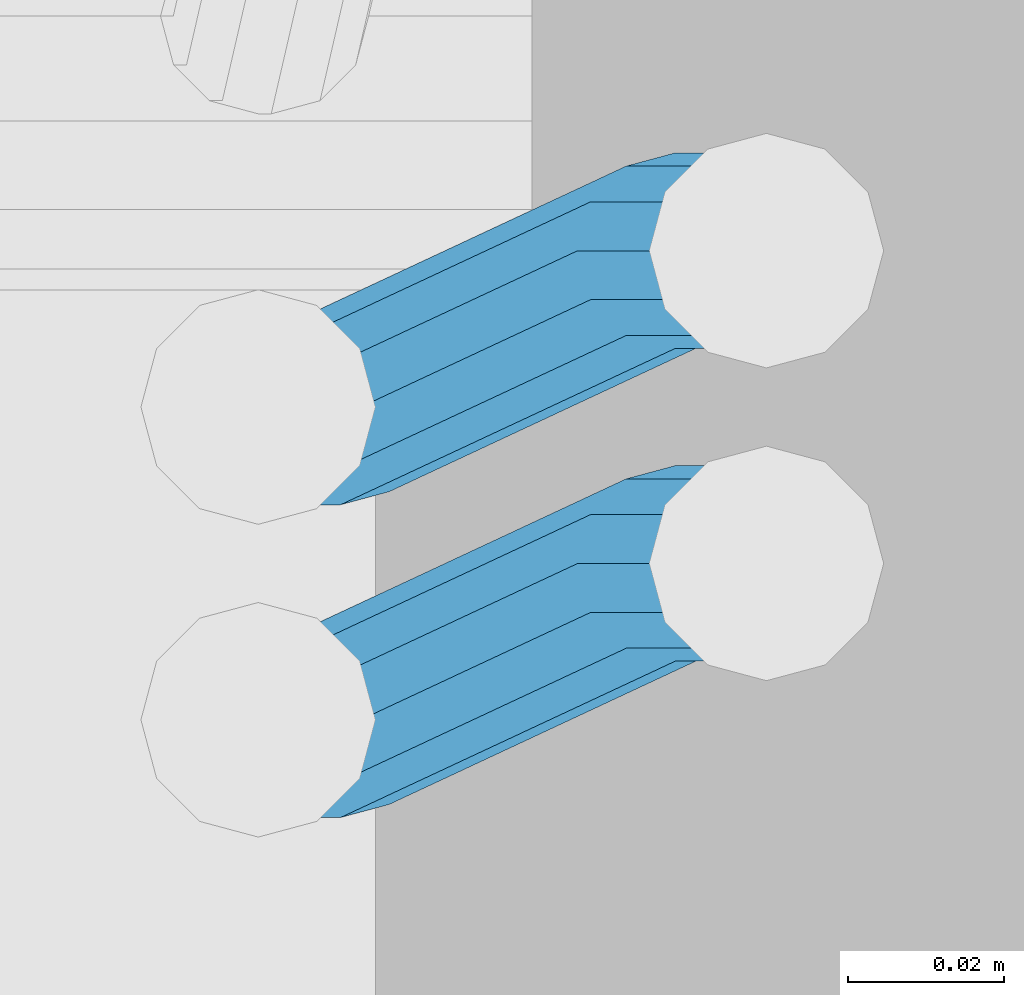
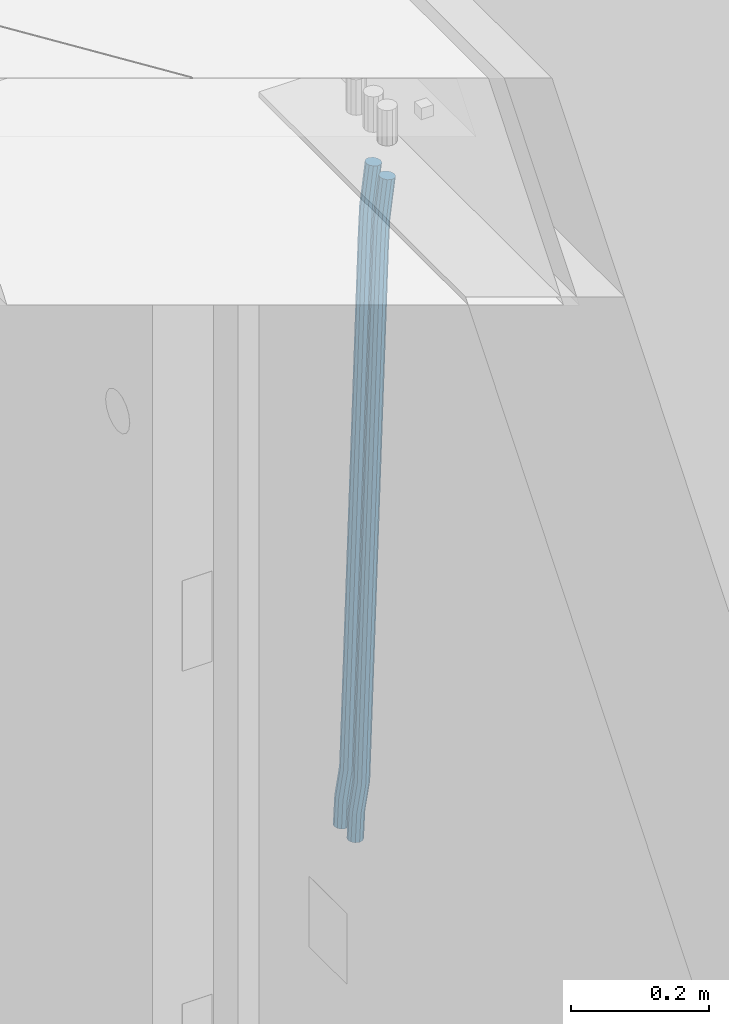
# One storey, part 103 of 309: 2 beams, 1 element without a shape of its own.
"""IFC2X3 building model written with IfcOpenShell, lengths in millimetres."""

import ifcopenshell
import ifcopenshell.guid

model = None  # the IFC model being written
_history = None  # IfcOwnerHistory: only IFC2X3 demands one
_inside = {}  # id of a spatial element -> (the spatial element, [elements in it])
_under = {}  # id of a project, library or spatial element -> (it, [spatial elements below it])
_declared = {}  # id of a project -> (the project, [libraries it declares])
_typed = {}  # id of a type object -> (the type object, [elements of that type])
_made_of = {}  # id of a material, layer set ... -> (it, [elements and type objects made of it])


def new_model(schema):
    """Start an empty IFC model of exactly this schema.

    Asked for "IFC4X3", IfcOpenShell would pick the latest addendum, in which some entities
    have other attributes; the version numbers below select the first issue.
    IFC2X3 requires an IfcOwnerHistory on every rooted entity: one is made here for all.
    """
    global model, _history
    if schema == "IFC4X3":
        model = ifcopenshell.file(schema_version=(4, 3, 0, 0))
    else:
        model = ifcopenshell.file(schema=schema)
    _inside.clear()
    _under.clear()
    _declared.clear()
    _typed.clear()
    _made_of.clear()
    _history = None
    if model.schema == "IFC2X3":
        org = make("IfcOrganization", Name="unknown")
        user = make(
            "IfcPersonAndOrganization",
            ThePerson=make("IfcPerson", FamilyName="unknown"),
            TheOrganization=org,
        )
        app = make(
            "IfcApplication",
            ApplicationDeveloper=org,
            Version="unknown",
            ApplicationFullName="unknown",
            ApplicationIdentifier="unknown",
        )
        _history = make(
            "IfcOwnerHistory",
            OwningUser=user,
            OwningApplication=app,
            ChangeAction="ADDED",
            CreationDate=0,
        )
    return model


def make(cls, **values):
    """One entity of the class cls with the attributes given. An attribute that is None is left unset."""
    return model.create_entity(
        cls, **{name: value for name, value in values.items() if value is not None}
    )


def rooted(cls, **values):
    """An entity with a GlobalId (a new one), such as an element, a storey or a relation."""
    return make(cls, GlobalId=ifcopenshell.guid.new(), OwnerHistory=_history, **values)


def si_unit(unit_type, name, prefix=None):
    """IfcSIUnit, for example si_unit("LENGTHUNIT", "METRE", prefix="MILLI")."""
    return make("IfcSIUnit", UnitType=unit_type, Prefix=prefix, Name=name)


def assignment(units):
    """IfcUnitAssignment: the units of a project."""
    return None if units is None else make("IfcUnitAssignment", Units=units)


def point(xyz):
    """IfcCartesianPoint."""
    return None if xyz is None else make("IfcCartesianPoint", Coordinates=xyz)


def direction(xyz):
    """IfcDirection."""
    return None if xyz is None else make("IfcDirection", DirectionRatios=xyz)


def frame(location, z_axis=None, x_axis=None):
    """IfcAxis2Placement3D, a coordinate frame: its origin and axes. An axis left out is left unset."""
    return make(
        "IfcAxis2Placement3D",
        Location=point(location),
        Axis=direction(z_axis),
        RefDirection=direction(x_axis),
    )


def origin_with_axes():
    """The frame at (0, 0, 0) with the z axis (0, 0, 1) and the x axis (1, 0, 0) written out."""
    return frame((0.0, 0.0, 0.0), z_axis=(0.0, 0.0, 1.0), x_axis=(1.0, 0.0, 0.0))


def place(relative_to, where):
    """IfcLocalPlacement: puts the frame where relative to a parent placement (None: the world)."""
    return make(
        "IfcLocalPlacement", PlacementRelTo=relative_to, RelativePlacement=where
    )


def context(
    kind, dimensions, precision=None, world=None, true_north=None, identifier=None
):
    """IfcGeometricRepresentationContext, for example the 3D "Model" context."""
    return make(
        "IfcGeometricRepresentationContext",
        ContextIdentifier=identifier,
        ContextType=kind,
        CoordinateSpaceDimension=dimensions,
        Precision=precision,
        WorldCoordinateSystem=world,
        TrueNorth=true_north,
    )


def subcontext(parent, identifier, kind, view, scale=None):
    """IfcGeometricRepresentationSubContext, for example "Body" below "Model"."""
    return make(
        "IfcGeometricRepresentationSubContext",
        ContextIdentifier=identifier,
        ContextType=kind,
        ParentContext=parent,
        TargetScale=scale,
        TargetView=view,
    )


def project(units=None, contexts=None):
    """IfcProject with its units and contexts."""
    return rooted(
        "IfcProject",
        Name="project",
        RepresentationContexts=contexts,
        UnitsInContext=assignment(units),
    )


def spatial(cls, under=None, at=None, **own):
    """A site, building, storey or space (cls), placed at a placement, below another one or the project."""
    s = rooted(cls, ObjectPlacement=at, **own)
    if under is not None:
        _under.setdefault(under.id(), (under, []))[1].append(s)
    return s


def faces_of(points, faces, orient=None, outer=None):
    """IfcFace entities. A face is a list of loops; a loop is a list of indices into points, from 0.

    orient and outer hold one flag for each loop. By default every Orientation is true, the
    first loop of a face is its IfcFaceOuterBound and the others are IfcFaceBound.
    """
    made = []
    for i, loops in enumerate(faces):
        bounds = []
        for j, loop in enumerate(loops):
            is_outer = j == 0 if outer is None else outer[i][j]
            bounds.append(
                make(
                    "IfcFaceOuterBound" if is_outer else "IfcFaceBound",
                    Bound=make("IfcPolyLoop", Polygon=[points[k] for k in loop]),
                    Orientation=True if orient is None else orient[i][j],
                )
            )
        made.append(make("IfcFace", Bounds=bounds))
    return made


def faceted_brep(points, faces, orient=None, outer=None, voids=None):
    """IfcFacetedBrep: a solid bounded by flat faces; with voids (closed shells), ...WithVoids."""
    shared = [point(p) for p in points]
    hull = make("IfcClosedShell", CfsFaces=faces_of(shared, faces, orient, outer))
    if voids is None:
        return make("IfcFacetedBrep", Outer=hull)
    return make(
        "IfcFacetedBrepWithVoids",
        Outer=hull,
        Voids=[
            make(cls, CfsFaces=faces_of(shared, fs, o, b)) for cls, fs, o, b in voids
        ],
    )


def shape(context_of_items, identifier, shape_type, items):
    """IfcShapeRepresentation: the items that make up one representation, for example the "Body"."""
    return make(
        "IfcShapeRepresentation",
        ContextOfItems=context_of_items,
        RepresentationIdentifier=identifier,
        RepresentationType=shape_type,
        Items=items,
    )


def material(Name=None, Category=None):
    """IfcMaterial."""
    return make("IfcMaterial", Name=Name, Category=Category)


def made_of(thing, what):
    """Note that an element or type object is made of a material, layer set ...; save() writes the relation."""
    if what is not None:
        _made_of.setdefault(what.id(), (what, []))[1].append(thing)
    return thing


def type_object(cls, material=None, **own):
    """A type object (cls), such as IfcWallType, which elements share."""
    return made_of(rooted(cls, **own), material)


def element(
    cls,
    number,
    at=None,
    inside=None,
    cuts=None,
    type_object=None,
    material=None,
    context=None,
    identifier="Body",
    shape_type=None,
    held_by="IfcProductDefinitionShape",
    body=None,
    shapes=None,
    **own,
):
    """One element of the class cls, such as IfcWall. Its Tag is "e" and its number.

    at: its placement. inside: the storey or other place that contains it. cuts: it is an
    opening in that element (IfcRelVoidsElement). A single representation is given by context,
    identifier, shape_type and body (its items); several are given by shapes. held_by: the class
    of the entity that holds the representations. save() writes the other relations.
    """
    e = rooted(cls, Tag="e%d" % number, ObjectPlacement=at, **own)
    if body is not None:
        shapes = [shape(context, identifier, shape_type, body)]
    if shapes is not None:
        e.Representation = make(held_by, Representations=shapes)
    if inside is not None:
        _inside.setdefault(inside.id(), (inside, []))[1].append(e)
    if cuts is not None:
        rooted(
            "IfcRelVoidsElement", RelatingBuildingElement=cuts, RelatedOpeningElement=e
        )
    if type_object is not None:
        _typed.setdefault(type_object.id(), (type_object, []))[1].append(e)
    return made_of(e, material)


def aggregate(whole, parts):
    """IfcRelAggregates: a whole, such as a stair, and the parts it consists of."""
    return rooted("IfcRelAggregates", RelatingObject=whole, RelatedObjects=parts)


def save(model, path):
    """Write the relations noted so far, then the file.

    IfcRelAggregates (storeys below a building ...), IfcRelContainedInSpatialStructure (elements
    in a storey), IfcRelDefinesByType, IfcRelAssociatesMaterial and IfcRelDeclares: one each for
    every whole, place, type object, material and project.
    """
    for whole, parts in _under.values():
        aggregate(whole, parts)
    for where, things in _inside.values():
        rooted(
            "IfcRelContainedInSpatialStructure",
            RelatedElements=things,
            RelatingStructure=where,
        )
    for kind, things in _typed.values():
        rooted("IfcRelDefinesByType", RelatedObjects=things, RelatingType=kind)
    for what, things in _made_of.values():
        rooted("IfcRelAssociatesMaterial", RelatedObjects=things, RelatingMaterial=what)
    for by, libraries in _declared.values():
        rooted("IfcRelDeclares", RelatingContext=by, RelatedDefinitions=libraries)
    model.write(path)


model = new_model("IFC2X3")

# Units and contexts
model_context = context("Model", 3, precision=1e-05, world=origin_with_axes())
body_context = subcontext(model_context, "Body", "Model", "MODEL_VIEW")
ifc_project = project(units=[si_unit("LENGTHUNIT", "METRE", prefix="MILLI"), si_unit("AREAUNIT", "SQUARE_METRE"), si_unit("VOLUMEUNIT", "CUBIC_METRE"), si_unit("MASSUNIT", "GRAM", prefix="KILO"), si_unit("TIMEUNIT", "SECOND"), si_unit("PLANEANGLEUNIT", "RADIAN"), si_unit("SOLIDANGLEUNIT", "STERADIAN"), si_unit("THERMODYNAMICTEMPERATUREUNIT", "DEGREE_CELSIUS"), si_unit("LUMINOUSINTENSITYUNIT", "LUMEN")], contexts=[model_context])

# Site, building, storey
site_placement = place(None, origin_with_axes())
site = spatial("IfcSite", under=ifc_project, at=site_placement, CompositionType="ELEMENT")
building_placement = place(site_placement, origin_with_axes())
building = spatial("IfcBuilding", under=site, at=building_placement, CompositionType="ELEMENT")
storey_placement = place(building_placement, origin_with_axes())
storey = spatial("IfcBuildingStorey", under=building, at=storey_placement, Name="7", CompositionType="ELEMENT", Elevation=0.0)

# Assembly, beams
assembly_placement = place(storey_placement, origin_with_axes())
assembly = element("IfcElementAssembly", 1, at=assembly_placement, inside=storey, AssemblyPlace="NOTDEFINED", PredefinedType="REINFORCEMENT_UNIT")
ifc_material = material()
beam_type = type_object("IfcBeamType", Name="D25", PredefinedType="NOTDEFINED")
beam_1_placement = place(assembly_placement, frame((17644.9989431251, 20156.4982803956, 101267.503552501), z_axis=(0.0, 1.0, 0.0), x_axis=(0.0467115440025518, 0.0, 0.998908420055061)))
beam_1 = element("IfcBeam", 2, at=beam_1_placement, type_object=beam_type, material=ifc_material, Name="JM25", ObjectType="D25", context=body_context, shape_type="Brep", body=[
    faceted_brep([(-7.41420080885291e-08, -12.5, -3.63797880709171e-12), (-6.42030499875546e-08, -10.8253175473074, -6.25000000000364), (48.7743672639481, -10.8253174221936, -6.25), (48.7743672682554, -12.4999998748863, 0.0), (-3.70782800018787e-08, -6.25000000000364, -10.8253175473074), (48.7743672522192, -6.24999987488263, -10.8253175473037), (-1.45519152283669e-11, -3.63797880709171e-12, -12.5), (48.7743672361976, 1.25113729154691e-07, -12.5), (3.70637280866504e-08, 6.25, -10.8253175473074), (48.7743672201614, 6.25000012511737, -10.8253175473037), (6.42030499875546e-08, 10.8253175473001, -6.25000000000364), (48.774367208418, 10.8253176724174, -6.25), (7.41420080885291e-08, 12.4999999999927, 0.0), (48.7743672041252, 12.5000001251174, 0.0), (6.42176019027829e-08, 10.8253175473001, 6.24999999999636), (48.774367208418, 10.8253176724174, 6.25), (3.70928319171071e-08, 6.24999999999636, 10.8253175473037), (48.7743672201614, 6.25000012511737, 10.8253175473037), (1.45519152283669e-11, -3.63797880709171e-12, 12.4999999999964), (48.7743672361976, 1.25113729154691e-07, 12.5), (-3.7049176171422e-08, -6.25000000000364, 10.8253175473001), (48.7743672522192, -6.24999987488263, 10.8253175473037), (-6.41884980723262e-08, -10.8253175473074, 6.25), (48.7743672639481, -10.8253174221936, 6.25), (50.6284132863948, -10.8253174174351, -6.25), (50.7256294211547, -12.4999998698804, 0.0), (50.362813866901, -6.2499998708081, -10.8253175473037), (49.9999983126327, 1.28262399812229e-07, -12.5), (49.6371827583935, 6.25000012732926, -10.8253175473037), (49.3715833388851, 10.8253176739527, -6.25), (49.2743672041252, 12.5000001264016, 0.0), (49.3715833388851, 10.8253176739527, 6.25), (49.6371827583935, 6.25000012732926, 10.8253175473037), (49.9999983126327, 1.28262399812229e-07, 12.5), (50.362813866901, -6.2499998708081, 10.8253175473037), (50.6284132863948, -10.8253174174351, 6.25), (52.4700055286376, -10.6107838149001, -6.25), (52.6637847850943, -12.2742172873113, 0.0), (51.9405907545442, -6.0661990532717, -10.8253175473037), (51.2173967239651, 0.141819180764287, -12.5), (50.494202693415, 6.34983741480755, -10.8253175473037), (49.9647879192926, 10.8944221764359, -6.25), (49.7710086628358, 12.5578556488472, 0.0), (49.9647879192926, 10.8944221764359, 6.25), (50.494202693415, 6.34983741480755, 10.8253175473037), (51.2173967239651, 0.141819180764287, 12.5), (51.9405907545442, -6.0661990532717, 10.8253175473037), (52.4700055286376, -10.6107838149037, 6.25), (100.1682419055, -5.05424733003747, -6.25), (100.362021161956, -6.71768080244692, 0.0), (99.6388271314063, -0.509662568409112, -10.8253175473037), (98.9156331008271, 5.69835566563052, -12.5), (98.192439070277, 11.9063738996665, -10.8253175473037), (97.6630242961546, 16.4509586612985, -6.25), (97.4692450396979, 18.1143921337098, 0.0), (97.6630242961546, 16.4509586612985, 6.25), (98.192439070277, 11.9063738996665, 10.8253175473037), (98.9156331008271, 5.69835566563052, 12.5), (99.6388271314063, -0.509662568409112, 10.8253175473037), (100.1682419055, -5.05424733003747, 6.25), (100.829389846811, -4.97722786481609, -6.25), (100.858662620667, -6.65982528000313, 0.0), (100.613505361369, -0.39611884945225, -10.8253175473037), (100.268855237926, 5.8559973049887, -12.5), (99.8877881987282, 12.1038711239344, -10.8253175473037), (99.5724108491268, 16.6733898631865, -6.25), (99.4072282953421, 18.3401546667665, 0.0), (99.4365010692127, 16.6575572515831, 6.25), (99.6523855546402, 12.0764482362174, 10.8253175473037), (99.9970356780832, 5.82433208178009, 12.5), (100.37810271731, -0.423541737165579, 10.8253175473037), (100.693480066882, -4.99306047642312, 6.25), (101.494850382805, -4.9772278650471, -6.23547852116099), (101.358543616545, -6.65982528017412, 0.0109082521194068), (101.594541309358, -0.396118849792401, -10.8039096771354), (101.63090429295, 5.85599730451395, -12.4702777768798), (101.594195901474, 12.1038711233377, -10.7880808337759), (101.49425211882, 16.6733898625134, -6.2080621602363), (101.357852800793, 18.340154666088, 0.0425659388420172), (101.221546034547, 16.6575572509591, 6.28895271212241), (101.121855107995, 12.0764482357044, 10.8573838680968), (101.085492124403, 5.82433208139992, 12.5237519678412), (101.122200515863, -0.423541737425694, 10.8415550247373), (101.222144298532, -4.99306047660866, 6.26153635119772), (1016.15234243186, -4.97722818425427, 13.7239010304511), (1016.01603566563, -6.65982559938311, 19.9702878037351), (1016.25203335841, -0.396119168995938, 9.15546987447669), (1016.28839634202, 5.85599698530859, 7.48910177473226), (1016.25168795056, 12.1038708041378, 9.17129871783618), (1016.15174416787, 16.6733895433135, 13.7513173913758), (1016.01534484986, 18.3401543468826, 20.0019454904541), (1015.8790380836, 16.6575569317556, 26.2483322637381), (1015.77934715705, 12.0764479165045, 30.8167634197125), (1015.74298417347, 5.82433176219456, 32.4831315194569), (1015.77969256493, -0.423542056632868, 30.8009345763494), (1015.8796363476, -4.99306079580856, 26.2209159028134), (1016.72024271244, -4.97722818445254, 13.7362935788587), (1016.65208128402, -6.65982559960139, 19.984167399125), (1016.77009392806, -0.396119169179656, 9.16677483576495), (1016.7882773379, 5.85599698513579, 7.50001002685531), (1016.76992071191, 12.1038708039559, 9.18260743664359), (1016.71994269331, 16.6733895431171, 13.7637164479929), (1016.65173485172, 18.3401543466607, 20.015832600875), (1016.58357342328, 16.65755693151, 26.2637064211413), (1016.53372220766, 12.0764479162353, 30.833225164235), (1016.51553879784, 5.82433176192717, 32.4999899731447), (1016.53389542381, -0.423542056894803, 30.8173925633564), (1016.58387344243, -4.99306079605594, 26.2362835520071), (1017.28827819017, -4.97722813975997, 13.7362935788587), (1017.28827832255, -6.6598255495519, 19.984167399125), (1017.28827782976, -0.396119128414284, 9.16677483576495), (1017.28827733788, 5.85599702447144, 7.50001002685531), (1017.28827684635, 12.103870844734, 9.18260743664359), (1017.28827648686, 16.6733895878278, 13.7637164479929), (1017.28827635571, 18.3401543967448, 20.015832600875), (1017.28827648809, 16.657556986951, 26.2637064211413), (1017.2882768485, 12.0764479756035, 30.833225164235), (1017.28827734038, 5.8243318227178, 32.4999899731447), (1017.28827783192, -0.423541997544817, 30.8173925633564), (1017.28827819142, -4.99306074063679, 26.2362835520071), (1065.6667756622, -4.97722433367016, 13.7362935788587), (1065.66677579457, -6.65982174345845, 19.984167399125), (1065.6667753018, -0.3961153223172, 9.16677483576495), (1065.66677480991, 5.85600083056488, 7.50001002685531), (1065.66677431838, 12.1038746508275, 9.18260743664359), (1065.66677395887, 16.6733933939249, 13.7637164479929), (1065.66677382775, 18.3401582028346, 20.015832600875), (1065.66677396011, 16.6575607930445, 26.2637064211413), (1065.66677432053, 12.0764517816933, 30.833225164235), (1065.6667748124, 5.82433562881488, 32.4999899731447), (1065.66677530395, -0.423538191451371, 30.8173925633564), (1065.66677566344, -4.99305693454517, 26.2362835520071), (1067.07165110651, -4.97722422314291, 13.7362935788587), (1067.13694763639, -6.65982162779255, 19.984167399125), (1066.89387208481, -0.396115225779795, 9.16677483576495), (1066.6512463166, 5.85600090801745, 7.50001002685531), (1066.40878518049, 12.1038747092061, 9.18260743664359), (1066.23145594214, 16.6733934383519, 13.7637164479929), (1066.16677382775, 18.340158242172, 20.015832600875), (1066.23207035761, 16.6575608375188, 26.2637064211413), (1066.40984937931, 12.0764518401556, 30.833225164235), (1066.65247514757, 5.82433570636204, 32.4999899731447), (1066.89493628364, -0.423538094826654, 30.8173925633564), (1067.07226552199, -4.99305682397062, 26.2362835520071), (1068.47230333716, -4.86837412698696, 13.736334784764), (1068.60269804588, -6.54588751704068, 19.9842150143704), (1068.11728165975, -0.301059828409052, 9.16679859123906), (1067.63276078545, 5.93224720081525, 7.50000996663584), (1067.14856769117, 12.161337376032, 9.18258357686864), (1066.79444152558, 16.7171310152116, 13.7636751818718), (1066.66527010873, 18.3789068918468, 20.0157849856296), (1066.79566481744, 16.7013935018003, 26.263665215236), (1067.15068649485, 12.134079203217, 30.8332014087609), (1067.63520736917, 5.90077217399266, 32.4999900333642), (1068.11940046342, -0.328318001224034, 30.8174164231314), (1068.47352662902, -4.88411164040008, 26.2363248181282), (1142.62319484423, 0.89544508106701, 13.736334784764), (1142.75358955294, -0.782068308983071, 19.9842150143704), (1142.26817316683, 5.4627593796431, 9.16679859123906), (1141.78365229251, 11.6960664088729, 7.50000996663584), (1141.29945919824, 17.9251565840896, 9.18258357686864), (1140.94533303265, 22.4809502232638, 13.7636751818718), (1140.81616161579, 24.1427260999008, 20.0157849856296), (1140.94655632452, 22.4652127098525, 26.263665215236), (1141.30157800192, 17.8978984112746, 30.8332014087609), (1141.78609887623, 11.6645913820466, 32.4999900333642), (1142.27029197049, 5.43550120682994, 30.8174164231314), (1142.6244181361, 0.879707567652076, 26.2363248181282)], [[[0, 1, 2, 3]], [[1, 4, 5, 2]], [[4, 6, 7, 5]], [[6, 8, 9, 7]], [[8, 10, 11, 9]], [[10, 12, 13, 11]], [[12, 14, 15, 13]], [[14, 16, 17, 15]], [[16, 18, 19, 17]], [[18, 20, 21, 19]], [[20, 22, 23, 21]], [[22, 0, 3, 23]], [[22, 20, 18, 16, 14, 12, 10, 8, 6, 4, 1, 0]], [[3, 2, 24, 25]], [[2, 5, 26, 24]], [[5, 7, 27, 26]], [[7, 9, 28, 27]], [[9, 11, 29, 28]], [[11, 13, 30, 29]], [[13, 15, 31, 30]], [[15, 17, 32, 31]], [[17, 19, 33, 32]], [[19, 21, 34, 33]], [[21, 23, 35, 34]], [[23, 3, 25, 35]], [[25, 24, 36, 37]], [[24, 26, 38, 36]], [[26, 27, 39, 38]], [[27, 28, 40, 39]], [[28, 29, 41, 40]], [[29, 30, 42, 41]], [[30, 31, 43, 42]], [[31, 32, 44, 43]], [[32, 33, 45, 44]], [[33, 34, 46, 45]], [[34, 35, 47, 46]], [[35, 25, 37, 47]], [[37, 36, 48, 49]], [[36, 38, 50, 48]], [[38, 39, 51, 50]], [[39, 40, 52, 51]], [[40, 41, 53, 52]], [[41, 42, 54, 53]], [[42, 43, 55, 54]], [[43, 44, 56, 55]], [[44, 45, 57, 56]], [[45, 46, 58, 57]], [[46, 47, 59, 58]], [[47, 37, 49, 59]], [[49, 48, 60, 61]], [[48, 50, 62, 60]], [[50, 51, 63, 62]], [[51, 52, 64, 63]], [[52, 53, 65, 64]], [[53, 54, 66, 65]], [[54, 55, 67, 66]], [[55, 56, 68, 67]], [[56, 57, 69, 68]], [[57, 58, 70, 69]], [[58, 59, 71, 70]], [[59, 49, 61, 71]], [[61, 60, 72, 73]], [[60, 62, 74, 72]], [[62, 63, 75, 74]], [[63, 64, 76, 75]], [[64, 65, 77, 76]], [[65, 66, 78, 77]], [[66, 67, 79, 78]], [[67, 68, 80, 79]], [[68, 69, 81, 80]], [[69, 70, 82, 81]], [[70, 71, 83, 82]], [[71, 61, 73, 83]], [[73, 72, 84, 85]], [[72, 74, 86, 84]], [[74, 75, 87, 86]], [[75, 76, 88, 87]], [[76, 77, 89, 88]], [[77, 78, 90, 89]], [[78, 79, 91, 90]], [[79, 80, 92, 91]], [[80, 81, 93, 92]], [[81, 82, 94, 93]], [[82, 83, 95, 94]], [[83, 73, 85, 95]], [[85, 84, 96, 97]], [[84, 86, 98, 96]], [[86, 87, 99, 98]], [[87, 88, 100, 99]], [[88, 89, 101, 100]], [[89, 90, 102, 101]], [[90, 91, 103, 102]], [[91, 92, 104, 103]], [[92, 93, 105, 104]], [[93, 94, 106, 105]], [[94, 95, 107, 106]], [[95, 85, 97, 107]], [[97, 96, 108, 109]], [[96, 98, 110, 108]], [[98, 99, 111, 110]], [[99, 100, 112, 111]], [[100, 101, 113, 112]], [[101, 102, 114, 113]], [[102, 103, 115, 114]], [[103, 104, 116, 115]], [[104, 105, 117, 116]], [[105, 106, 118, 117]], [[106, 107, 119, 118]], [[107, 97, 109, 119]], [[109, 108, 120, 121]], [[108, 110, 122, 120]], [[110, 111, 123, 122]], [[111, 112, 124, 123]], [[112, 113, 125, 124]], [[113, 114, 126, 125]], [[114, 115, 127, 126]], [[115, 116, 128, 127]], [[116, 117, 129, 128]], [[117, 118, 130, 129]], [[118, 119, 131, 130]], [[119, 109, 121, 131]], [[121, 120, 132, 133]], [[120, 122, 134, 132]], [[122, 123, 135, 134]], [[123, 124, 136, 135]], [[124, 125, 137, 136]], [[125, 126, 138, 137]], [[126, 127, 139, 138]], [[127, 128, 140, 139]], [[128, 129, 141, 140]], [[129, 130, 142, 141]], [[130, 131, 143, 142]], [[131, 121, 133, 143]], [[133, 132, 144, 145]], [[132, 134, 146, 144]], [[134, 135, 147, 146]], [[135, 136, 148, 147]], [[136, 137, 149, 148]], [[137, 138, 150, 149]], [[138, 139, 151, 150]], [[139, 140, 152, 151]], [[140, 141, 153, 152]], [[141, 142, 154, 153]], [[142, 143, 155, 154]], [[143, 133, 145, 155]], [[145, 144, 156, 157]], [[144, 146, 158, 156]], [[146, 147, 159, 158]], [[147, 148, 160, 159]], [[148, 149, 161, 160]], [[149, 150, 162, 161]], [[150, 151, 163, 162]], [[151, 152, 164, 163]], [[152, 153, 165, 164]], [[153, 154, 166, 165]], [[154, 155, 167, 166]], [[155, 145, 157, 167]], [[158, 159, 160, 161, 162, 163, 164, 165, 166, 167, 157, 156]]]),
])
beam_2_placement = place(assembly_placement, frame((17644.9989431251, 20116.4982803956, 101267.503552501), z_axis=(0.0, 1.0, 0.0), x_axis=(0.0467115440025518, 0.0, 0.998908420055061)))
beam_2 = element("IfcBeam", 3, at=beam_2_placement, type_object=beam_type, material=ifc_material, Name="JM25", ObjectType="D25", context=body_context, shape_type="Brep", body=[
    faceted_brep([(-7.41420080885291e-08, -12.5, -3.63797880709171e-12), (-6.42030499875546e-08, -10.8253175473074, -6.25000000000364), (48.7743672639481, -10.8253174221936, -6.25), (48.7743672682554, -12.4999998748863, 0.0), (-3.70782800018787e-08, -6.25000000000364, -10.8253175473074), (48.7743672522192, -6.24999987488263, -10.8253175473037), (-1.45519152283669e-11, -3.63797880709171e-12, -12.5), (48.7743672361976, 1.25113729154691e-07, -12.5), (3.70637280866504e-08, 6.25, -10.8253175473074), (48.7743672201614, 6.25000012511737, -10.8253175473037), (6.42030499875546e-08, 10.8253175473001, -6.25000000000364), (48.774367208418, 10.8253176724174, -6.25), (7.41420080885291e-08, 12.4999999999927, 0.0), (48.7743672041252, 12.5000001251174, 0.0), (6.42176019027829e-08, 10.8253175473001, 6.24999999999636), (48.774367208418, 10.8253176724174, 6.25), (3.70928319171071e-08, 6.24999999999636, 10.8253175473037), (48.7743672201614, 6.25000012511737, 10.8253175473037), (1.45519152283669e-11, -3.63797880709171e-12, 12.4999999999964), (48.7743672361976, 1.25113729154691e-07, 12.5), (-3.7049176171422e-08, -6.25000000000364, 10.8253175473001), (48.7743672522192, -6.24999987488263, 10.8253175473037), (-6.41884980723262e-08, -10.8253175473074, 6.25), (48.7743672639481, -10.8253174221936, 6.25), (50.6284132863948, -10.8253174174351, -6.25), (50.7256294211547, -12.4999998698804, 0.0), (50.362813866901, -6.2499998708081, -10.8253175473037), (49.9999983126327, 1.28262399812229e-07, -12.5), (49.6371827583935, 6.25000012732926, -10.8253175473037), (49.3715833388851, 10.8253176739527, -6.25), (49.2743672041252, 12.5000001264016, 0.0), (49.3715833388851, 10.8253176739527, 6.25), (49.6371827583935, 6.25000012732926, 10.8253175473037), (49.9999983126327, 1.28262399812229e-07, 12.5), (50.362813866901, -6.2499998708081, 10.8253175473037), (50.6284132863948, -10.8253174174351, 6.25), (52.4700055286376, -10.6107838149001, -6.25), (52.6637847850943, -12.2742172873113, 0.0), (51.9405907545442, -6.0661990532717, -10.8253175473037), (51.2173967239651, 0.141819180764287, -12.5), (50.494202693415, 6.34983741480755, -10.8253175473037), (49.9647879192926, 10.8944221764359, -6.25), (49.7710086628358, 12.5578556488472, 0.0), (49.9647879192926, 10.8944221764359, 6.25), (50.494202693415, 6.34983741480755, 10.8253175473037), (51.2173967239651, 0.141819180764287, 12.5), (51.9405907545442, -6.0661990532717, 10.8253175473037), (52.4700055286376, -10.6107838149037, 6.25), (100.1682419055, -5.05424733003747, -6.25), (100.362021161956, -6.71768080244692, 0.0), (99.6388271314063, -0.509662568409112, -10.8253175473037), (98.9156331008271, 5.69835566563052, -12.5), (98.192439070277, 11.9063738996665, -10.8253175473037), (97.6630242961546, 16.4509586612985, -6.25), (97.4692450396979, 18.1143921337098, 0.0), (97.6630242961546, 16.4509586612985, 6.25), (98.192439070277, 11.9063738996665, 10.8253175473037), (98.9156331008271, 5.69835566563052, 12.5), (99.6388271314063, -0.509662568409112, 10.8253175473037), (100.1682419055, -5.05424733003747, 6.25), (100.829389846811, -4.97722786481609, -6.25), (100.858662620667, -6.65982528000313, 0.0), (100.613505361369, -0.39611884945225, -10.8253175473037), (100.268855237926, 5.8559973049887, -12.5), (99.8877881987282, 12.1038711239344, -10.8253175473037), (99.5724108491268, 16.6733898631865, -6.25), (99.4072282953421, 18.3401546667665, 0.0), (99.4365010692127, 16.6575572515831, 6.25), (99.6523855546402, 12.0764482362174, 10.8253175473037), (99.9970356780832, 5.82433208178009, 12.5), (100.37810271731, -0.423541737165579, 10.8253175473037), (100.693480066882, -4.99306047642312, 6.25), (101.494850382805, -4.9772278650471, -6.23547852116099), (101.358543616545, -6.65982528017412, 0.0109082521194068), (101.594541309358, -0.396118849792401, -10.8039096771354), (101.63090429295, 5.85599730451395, -12.4702777768798), (101.594195901474, 12.1038711233377, -10.7880808337759), (101.49425211882, 16.6733898625134, -6.2080621602363), (101.357852800793, 18.340154666088, 0.0425659388420172), (101.221546034547, 16.6575572509591, 6.28895271212241), (101.121855107995, 12.0764482357044, 10.8573838680968), (101.085492124403, 5.82433208139992, 12.5237519678412), (101.122200515863, -0.423541737425694, 10.8415550247373), (101.222144298532, -4.99306047660866, 6.26153635119772), (1016.15234243186, -4.97722818425427, 13.7239010304511), (1016.01603566563, -6.65982559938311, 19.9702878037351), (1016.25203335841, -0.396119168995938, 9.15546987447669), (1016.28839634202, 5.85599698530859, 7.48910177473226), (1016.25168795056, 12.1038708041378, 9.17129871783618), (1016.15174416787, 16.6733895433135, 13.7513173913758), (1016.01534484986, 18.3401543468826, 20.0019454904541), (1015.8790380836, 16.6575569317556, 26.2483322637381), (1015.77934715705, 12.0764479165045, 30.8167634197125), (1015.74298417347, 5.82433176219456, 32.4831315194569), (1015.77969256493, -0.423542056632868, 30.8009345763494), (1015.8796363476, -4.99306079580856, 26.2209159028134), (1016.72024271244, -4.97722818445254, 13.7362935788587), (1016.65208128402, -6.65982559960139, 19.984167399125), (1016.77009392806, -0.396119169179656, 9.16677483576495), (1016.7882773379, 5.85599698513579, 7.50001002685531), (1016.76992071191, 12.1038708039559, 9.18260743664359), (1016.71994269331, 16.6733895431171, 13.7637164479929), (1016.65173485172, 18.3401543466607, 20.015832600875), (1016.58357342328, 16.65755693151, 26.2637064211413), (1016.53372220766, 12.0764479162353, 30.833225164235), (1016.51553879784, 5.82433176192717, 32.4999899731447), (1016.53389542381, -0.423542056894803, 30.8173925633564), (1016.58387344243, -4.99306079605594, 26.2362835520071), (1017.28827819017, -4.97722813975997, 13.7362935788587), (1017.28827832255, -6.6598255495519, 19.984167399125), (1017.28827782976, -0.396119128414284, 9.16677483576495), (1017.28827733788, 5.85599702447144, 7.50001002685531), (1017.28827684635, 12.103870844734, 9.18260743664359), (1017.28827648686, 16.6733895878278, 13.7637164479929), (1017.28827635571, 18.3401543967448, 20.015832600875), (1017.28827648809, 16.657556986951, 26.2637064211413), (1017.2882768485, 12.0764479756035, 30.833225164235), (1017.28827734038, 5.8243318227178, 32.4999899731447), (1017.28827783192, -0.423541997544817, 30.8173925633564), (1017.28827819142, -4.99306074063679, 26.2362835520071), (1065.6667756622, -4.97722433367016, 13.7362935788587), (1065.66677579457, -6.65982174345845, 19.984167399125), (1065.6667753018, -0.3961153223172, 9.16677483576495), (1065.66677480991, 5.85600083056488, 7.50001002685531), (1065.66677431838, 12.1038746508275, 9.18260743664359), (1065.66677395887, 16.6733933939249, 13.7637164479929), (1065.66677382775, 18.3401582028346, 20.015832600875), (1065.66677396011, 16.6575607930445, 26.2637064211413), (1065.66677432053, 12.0764517816933, 30.833225164235), (1065.6667748124, 5.82433562881488, 32.4999899731447), (1065.66677530395, -0.423538191451371, 30.8173925633564), (1065.66677566344, -4.99305693454517, 26.2362835520071), (1067.07165110651, -4.97722422314291, 13.7362935788587), (1067.13694763639, -6.65982162779255, 19.984167399125), (1066.89387208481, -0.396115225779795, 9.16677483576495), (1066.6512463166, 5.85600090801745, 7.50001002685531), (1066.40878518049, 12.1038747092061, 9.18260743664359), (1066.23145594214, 16.6733934383519, 13.7637164479929), (1066.16677382775, 18.340158242172, 20.015832600875), (1066.23207035761, 16.6575608375188, 26.2637064211413), (1066.40984937931, 12.0764518401556, 30.833225164235), (1066.65247514757, 5.82433570636204, 32.4999899731447), (1066.89493628364, -0.423538094826654, 30.8173925633564), (1067.07226552199, -4.99305682397062, 26.2362835520071), (1068.47230333716, -4.86837412698696, 13.736334784764), (1068.60269804588, -6.54588751704068, 19.9842150143704), (1068.11728165975, -0.301059828409052, 9.16679859123906), (1067.63276078545, 5.93224720081525, 7.50000996663584), (1067.14856769117, 12.161337376032, 9.18258357686864), (1066.79444152558, 16.7171310152116, 13.7636751818718), (1066.66527010873, 18.3789068918468, 20.0157849856296), (1066.79566481744, 16.7013935018003, 26.263665215236), (1067.15068649485, 12.134079203217, 30.8332014087609), (1067.63520736917, 5.90077217399266, 32.4999900333642), (1068.11940046342, -0.328318001224034, 30.8174164231314), (1068.47352662902, -4.88411164040008, 26.2363248181282), (1142.62319484423, 0.89544508106701, 13.736334784764), (1142.75358955294, -0.782068308983071, 19.9842150143704), (1142.26817316683, 5.4627593796431, 9.16679859123906), (1141.78365229251, 11.6960664088729, 7.50000996663584), (1141.29945919824, 17.9251565840896, 9.18258357686864), (1140.94533303265, 22.4809502232638, 13.7636751818718), (1140.81616161579, 24.1427260999008, 20.0157849856296), (1140.94655632452, 22.4652127098525, 26.263665215236), (1141.30157800192, 17.8978984112746, 30.8332014087609), (1141.78609887623, 11.6645913820466, 32.4999900333642), (1142.27029197049, 5.43550120682994, 30.8174164231314), (1142.6244181361, 0.879707567652076, 26.2363248181282)], [[[0, 1, 2, 3]], [[1, 4, 5, 2]], [[4, 6, 7, 5]], [[6, 8, 9, 7]], [[8, 10, 11, 9]], [[10, 12, 13, 11]], [[12, 14, 15, 13]], [[14, 16, 17, 15]], [[16, 18, 19, 17]], [[18, 20, 21, 19]], [[20, 22, 23, 21]], [[22, 0, 3, 23]], [[22, 20, 18, 16, 14, 12, 10, 8, 6, 4, 1, 0]], [[3, 2, 24, 25]], [[2, 5, 26, 24]], [[5, 7, 27, 26]], [[7, 9, 28, 27]], [[9, 11, 29, 28]], [[11, 13, 30, 29]], [[13, 15, 31, 30]], [[15, 17, 32, 31]], [[17, 19, 33, 32]], [[19, 21, 34, 33]], [[21, 23, 35, 34]], [[23, 3, 25, 35]], [[25, 24, 36, 37]], [[24, 26, 38, 36]], [[26, 27, 39, 38]], [[27, 28, 40, 39]], [[28, 29, 41, 40]], [[29, 30, 42, 41]], [[30, 31, 43, 42]], [[31, 32, 44, 43]], [[32, 33, 45, 44]], [[33, 34, 46, 45]], [[34, 35, 47, 46]], [[35, 25, 37, 47]], [[37, 36, 48, 49]], [[36, 38, 50, 48]], [[38, 39, 51, 50]], [[39, 40, 52, 51]], [[40, 41, 53, 52]], [[41, 42, 54, 53]], [[42, 43, 55, 54]], [[43, 44, 56, 55]], [[44, 45, 57, 56]], [[45, 46, 58, 57]], [[46, 47, 59, 58]], [[47, 37, 49, 59]], [[49, 48, 60, 61]], [[48, 50, 62, 60]], [[50, 51, 63, 62]], [[51, 52, 64, 63]], [[52, 53, 65, 64]], [[53, 54, 66, 65]], [[54, 55, 67, 66]], [[55, 56, 68, 67]], [[56, 57, 69, 68]], [[57, 58, 70, 69]], [[58, 59, 71, 70]], [[59, 49, 61, 71]], [[61, 60, 72, 73]], [[60, 62, 74, 72]], [[62, 63, 75, 74]], [[63, 64, 76, 75]], [[64, 65, 77, 76]], [[65, 66, 78, 77]], [[66, 67, 79, 78]], [[67, 68, 80, 79]], [[68, 69, 81, 80]], [[69, 70, 82, 81]], [[70, 71, 83, 82]], [[71, 61, 73, 83]], [[73, 72, 84, 85]], [[72, 74, 86, 84]], [[74, 75, 87, 86]], [[75, 76, 88, 87]], [[76, 77, 89, 88]], [[77, 78, 90, 89]], [[78, 79, 91, 90]], [[79, 80, 92, 91]], [[80, 81, 93, 92]], [[81, 82, 94, 93]], [[82, 83, 95, 94]], [[83, 73, 85, 95]], [[85, 84, 96, 97]], [[84, 86, 98, 96]], [[86, 87, 99, 98]], [[87, 88, 100, 99]], [[88, 89, 101, 100]], [[89, 90, 102, 101]], [[90, 91, 103, 102]], [[91, 92, 104, 103]], [[92, 93, 105, 104]], [[93, 94, 106, 105]], [[94, 95, 107, 106]], [[95, 85, 97, 107]], [[97, 96, 108, 109]], [[96, 98, 110, 108]], [[98, 99, 111, 110]], [[99, 100, 112, 111]], [[100, 101, 113, 112]], [[101, 102, 114, 113]], [[102, 103, 115, 114]], [[103, 104, 116, 115]], [[104, 105, 117, 116]], [[105, 106, 118, 117]], [[106, 107, 119, 118]], [[107, 97, 109, 119]], [[109, 108, 120, 121]], [[108, 110, 122, 120]], [[110, 111, 123, 122]], [[111, 112, 124, 123]], [[112, 113, 125, 124]], [[113, 114, 126, 125]], [[114, 115, 127, 126]], [[115, 116, 128, 127]], [[116, 117, 129, 128]], [[117, 118, 130, 129]], [[118, 119, 131, 130]], [[119, 109, 121, 131]], [[121, 120, 132, 133]], [[120, 122, 134, 132]], [[122, 123, 135, 134]], [[123, 124, 136, 135]], [[124, 125, 137, 136]], [[125, 126, 138, 137]], [[126, 127, 139, 138]], [[127, 128, 140, 139]], [[128, 129, 141, 140]], [[129, 130, 142, 141]], [[130, 131, 143, 142]], [[131, 121, 133, 143]], [[133, 132, 144, 145]], [[132, 134, 146, 144]], [[134, 135, 147, 146]], [[135, 136, 148, 147]], [[136, 137, 149, 148]], [[137, 138, 150, 149]], [[138, 139, 151, 150]], [[139, 140, 152, 151]], [[140, 141, 153, 152]], [[141, 142, 154, 153]], [[142, 143, 155, 154]], [[143, 133, 145, 155]], [[145, 144, 156, 157]], [[144, 146, 158, 156]], [[146, 147, 159, 158]], [[147, 148, 160, 159]], [[148, 149, 161, 160]], [[149, 150, 162, 161]], [[150, 151, 163, 162]], [[151, 152, 164, 163]], [[152, 153, 165, 164]], [[153, 154, 166, 165]], [[154, 155, 167, 166]], [[155, 145, 157, 167]], [[158, 159, 160, 161, 162, 163, 164, 165, 166, 167, 157, 156]]]),
])
aggregate(assembly, [beam_1, beam_2])

save(model, "model.ifc")
